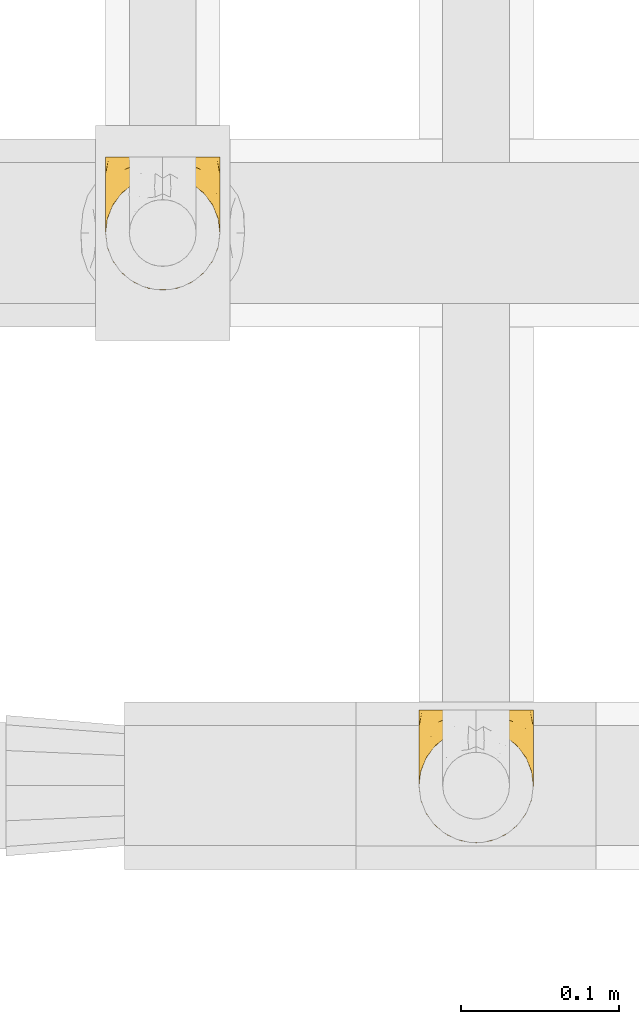
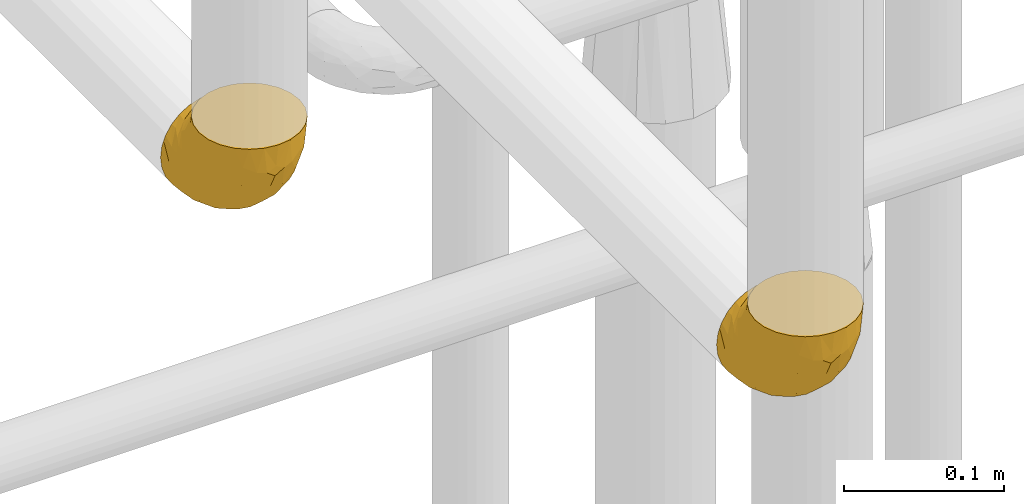
# One storey, part 127 of 827: 2 coverings.
"""IFC2X3 building model written with IfcOpenShell, lengths in millimetres."""

from ifc_helpers import new_model, entity, si_unit, converted_unit, derived_unit, direction, frame, origin, place, context, subcontext, project, spatial, faceted_brep, element, save


model = new_model("IFC2X3")

# Units and contexts
model_context = context("Model", 3, precision=0.01, world=origin(), true_north=direction((6.12303176911189e-17, 1.0)))
body_context = subcontext(model_context, "Body", "Model", "MODEL_VIEW")
ifc_project = project(units=[si_unit("LENGTHUNIT", "METRE", prefix="MILLI"), si_unit("AREAUNIT", "SQUARE_METRE"), si_unit("VOLUMEUNIT", "CUBIC_METRE"), converted_unit("PLANEANGLEUNIT", "DEGREE", entity("IfcRatioMeasure", 0.0174532925199433), si_unit("PLANEANGLEUNIT", "RADIAN"), dimensions=[0, 0, 0, 0, 0, 0, 0]), si_unit("MASSUNIT", "GRAM", prefix="KILO"), derived_unit("MASSDENSITYUNIT", [(si_unit("MASSUNIT", "GRAM", prefix="KILO"), 1), (si_unit("LENGTHUNIT", "METRE"), -3)]), derived_unit("MOMENTOFINERTIAUNIT", [(si_unit("LENGTHUNIT", "METRE"), 4)]), si_unit("TIMEUNIT", "SECOND"), si_unit("FREQUENCYUNIT", "HERTZ"), si_unit("THERMODYNAMICTEMPERATUREUNIT", "DEGREE_CELSIUS"), derived_unit("THERMALTRANSMITTANCEUNIT", [(si_unit("MASSUNIT", "GRAM", prefix="KILO"), 1), (si_unit("THERMODYNAMICTEMPERATUREUNIT", "KELVIN"), -1), (si_unit("TIMEUNIT", "SECOND"), -3)]), derived_unit("VOLUMETRICFLOWRATEUNIT", [(si_unit("LENGTHUNIT", "METRE"), 3), (si_unit("TIMEUNIT", "SECOND"), -1)]), derived_unit("MASSFLOWRATEUNIT", [(si_unit("MASSUNIT", "GRAM", prefix="KILO"), 1), (si_unit("TIMEUNIT", "SECOND"), -1)]), derived_unit("ROTATIONALFREQUENCYUNIT", [(si_unit("TIMEUNIT", "SECOND"), -1)]), si_unit("ELECTRICCURRENTUNIT", "AMPERE"), si_unit("ELECTRICVOLTAGEUNIT", "VOLT"), si_unit("POWERUNIT", "WATT"), si_unit("FORCEUNIT", "NEWTON", prefix="KILO"), si_unit("ILLUMINANCEUNIT", "LUX"), si_unit("LUMINOUSFLUXUNIT", "LUMEN"), si_unit("LUMINOUSINTENSITYUNIT", "CANDELA"), derived_unit("USERDEFINED", [(si_unit("MASSUNIT", "GRAM", prefix="KILO"), -1), (si_unit("LENGTHUNIT", "METRE"), -2), (si_unit("TIMEUNIT", "SECOND"), 3), (si_unit("LUMINOUSFLUXUNIT", "LUMEN"), 1)]), derived_unit("LINEARVELOCITYUNIT", [(si_unit("LENGTHUNIT", "METRE"), 1), (si_unit("TIMEUNIT", "SECOND"), -1)]), si_unit("PRESSUREUNIT", "PASCAL"), derived_unit("USERDEFINED", [(si_unit("LENGTHUNIT", "METRE"), -2), (si_unit("MASSUNIT", "GRAM", prefix="KILO"), 1), (si_unit("TIMEUNIT", "SECOND"), -2)]), derived_unit("LINEARFORCEUNIT", [(si_unit("MASSUNIT", "GRAM", prefix="KILO"), 1), (si_unit("LENGTHUNIT", "METRE"), 1), (si_unit("TIMEUNIT", "SECOND"), -2), (si_unit("LENGTHUNIT", "METRE"), -1)]), derived_unit("PLANARFORCEUNIT", [(si_unit("MASSUNIT", "GRAM", prefix="KILO"), 1), (si_unit("LENGTHUNIT", "METRE"), 1), (si_unit("TIMEUNIT", "SECOND"), -2), (si_unit("LENGTHUNIT", "METRE"), -2)])], contexts=[model_context])

# Site, building, storey
site_placement = place(None, origin())
site = spatial("IfcSite", under=ifc_project, at=site_placement, CompositionType="ELEMENT")
building_placement = place(site_placement, origin())
building = spatial("IfcBuilding", under=site, at=building_placement, CompositionType="ELEMENT")
storey_placement = place(building_placement, frame((0.0, 0.0, 28200.0)))
storey = spatial("IfcBuildingStorey", under=building, at=storey_placement, Name="08", CompositionType="ELEMENT", Elevation=28200.0)

# Coverings
covering_1_placement = place(storey_placement, frame((17030.57, 14712.0, 2362.2)))
element("IfcCovering", 1, at=covering_1_placement, inside=storey, Name=":ADSK_", ObjectType=":ADSK_", PredefinedType="INSULATION", context=body_context, shape_type="Brep", body=[
    faceted_brep([(74.0, 85.8, 37.8), (73.09, 85.8, 29.74), (70.41, 85.8, 22.08), (66.09, 85.8, 15.22), (60.36, 85.8, 9.49), (53.5, 85.8, 5.18), (45.85, 85.8, 2.5), (37.8, 85.8, 1.6), (29.74, 85.8, 2.5), (22.08, 85.8, 5.18), (15.22, 85.8, 9.5), (9.49, 85.8, 15.23), (5.18, 85.8, 22.09), (2.5, 85.8, 29.74), (1.6, 85.8, 37.8), (2.19, 85.8, 43.06), (2.5, 85.8, 45.85), (3.84, 85.8, 49.68), (5.18, 85.8, 53.51), (9.5, 85.8, 60.37), (15.23, 85.8, 66.1), (22.09, 85.8, 70.41), (29.74, 85.8, 73.09), (37.8, 85.8, 74.0), (45.85, 85.8, 73.09), (53.51, 85.8, 70.41), (60.37, 85.8, 66.09), (66.1, 85.8, 60.36), (70.41, 85.8, 53.5), (71.75, 85.8, 49.67), (73.09, 85.8, 45.85), (73.4, 85.8, 43.06), (28.43, 72.76, 85.8), (19.7, 69.15, 85.8), (12.2, 63.39, 85.8), (9.32, 59.64, 85.8), (6.45, 55.9, 85.8), (4.64, 51.53, 85.8), (2.83, 47.16, 85.8), (2.29, 43.08, 85.8), (1.94, 40.44, 85.8), (1.6, 37.8, 85.8), (2.83, 28.43, 85.8), (6.45, 19.7, 85.8), (12.2, 12.2, 85.8), (19.7, 6.45, 85.8), (28.43, 2.83, 85.8), (37.8, 1.6, 85.8), (47.16, 2.83, 85.8), (55.9, 6.45, 85.8), (63.39, 12.2, 85.8), (69.15, 19.7, 85.8), (72.76, 28.43, 85.8), (74.0, 37.8, 85.8), (73.3, 43.08, 85.8), (72.76, 47.16, 85.8), (70.95, 51.53, 85.8), (69.15, 55.9, 85.8), (66.27, 59.64, 85.8), (63.39, 63.39, 85.8), (55.9, 69.15, 85.8), (47.16, 72.76, 85.8), (37.8, 74.0, 85.8), (50.11, 27.78, 27.78), (37.8, 26.99, 26.99), (46.44, 36.07, 19.15), (37.8, 5.72, 59.78), (44.03, 4.9, 64.45), (37.8, 4.42, 67.99), (47.59, 13.52, 45.3), (57.17, 14.0, 53.86), (50.38, 6.28, 66.01), (58.65, 9.64, 70.92), (73.37, 70.93, 33.16), (71.27, 36.05, 49.16), (70.16, 24.02, 68.28), (66.97, 25.93, 50.64), (73.22, 32.56, 70.36), (74.0, 41.45, 67.43), (74.0, 39.97, 74.88), (74.0, 39.42, 77.61), (74.0, 38.88, 80.34), (64.86, 16.62, 65.68), (70.93, 71.64, 24.84), (45.19, 47.83, 11.5), (48.57, 65.91, 5.67), (54.32, 51.38, 13.35), (72.94, 52.81, 39.73), (74.0, 67.43, 41.45), (74.0, 63.53, 44.05), (74.0, 59.64, 46.65), (74.0, 55.75, 49.25), (74.0, 51.85, 51.85), (68.72, 41.26, 35.98), (73.34, 38.98, 57.18), (67.28, 70.65, 18.48), (61.7, 65.64, 13.36), (55.94, 71.08, 7.85), (37.8, 67.99, 4.42), (53.02, 38.62, 20.15), (57.31, 28.73, 31.91), (74.0, 80.34, 38.88), (74.0, 74.88, 39.97), (64.86, 52.52, 21.9), (59.15, 41.68, 22.4), (70.05, 56.44, 28.44), (55.98, 19.89, 41.69), (37.8, 11.7, 48.04), (63.54, 34.04, 33.67), (61.4, 22.66, 44.49), (37.8, 59.78, 5.72), (37.8, 36.3, 17.68), (37.8, 48.04, 11.7), (74.0, 49.25, 55.75), (74.0, 46.65, 59.64), (74.0, 44.05, 63.53), (37.8, 17.68, 36.3), (70.9, 56.47, 69.92), (69.2, 60.92, 69.03), (65.83, 63.29, 74.68), (73.31, 45.31, 79.55), (67.07, 59.83, 79.54), (62.53, 64.71, 81.25), (52.3, 74.49, 76.19), (54.94, 76.83, 72.4), (46.54, 78.01, 75.54), (72.14, 62.31, 57.77), (70.14, 62.83, 63.89), (73.22, 56.53, 57.73), (59.32, 71.99, 72.9), (56.36, 70.83, 77.88), (48.99, 73.18, 80.8), (58.36, 68.29, 80.78), (66.05, 80.74, 60.93), (61.56, 78.17, 66.56), (68.98, 73.83, 58.7), (73.26, 76.96, 46.01), (70.05, 54.72, 80.23), (73.39, 47.37, 70.42), (70.87, 54.39, 74.75), (61.17, 74.3, 68.99), (71.9, 75.54, 51.42), (65.19, 66.46, 71.01), (37.8, 80.75, 76.08), (46.04, 81.71, 73.72), (52.15, 81.69, 71.61), (66.57, 72.63, 63.33), (37.8, 77.45, 77.45), (73.34, 62.19, 52.1), (72.91, 67.73, 50.98), (37.8, 76.08, 80.75), (72.75, 48.26, 76.87), (66.28, 68.86, 66.53), (73.17, 50.18, 66.91), (72.08, 56.9, 63.7), (17.23, 68.29, 80.78), (26.6, 73.17, 80.8), (13.06, 64.71, 81.26), (1.6, 80.34, 38.88), (1.6, 74.88, 39.97), (29.56, 81.71, 73.72), (20.66, 76.83, 72.41), (23.45, 81.69, 71.61), (14.04, 78.17, 66.57), (1.6, 38.34, 83.07), (1.6, 39.97, 74.88), (1.6, 38.88, 80.34), (19.23, 70.83, 77.88), (23.3, 74.49, 76.2), (16.29, 72.0, 72.91), (8.09, 59.87, 77.2), (4.72, 54.39, 74.75), (5.54, 54.72, 80.23), (3.69, 75.53, 51.43), (2.84, 48.26, 76.87), (2.42, 50.18, 66.92), (4.69, 56.47, 69.93), (3.51, 56.9, 63.71), (2.2, 47.37, 70.42), (29.05, 78.01, 75.54), (2.29, 45.31, 79.55), (9.55, 80.74, 60.94), (14.43, 74.3, 69.0), (2.33, 76.96, 46.02), (3.45, 62.32, 57.77), (2.37, 56.54, 57.73), (5.45, 62.83, 63.89), (10.41, 66.46, 71.03), (2.81, 67.82, 51.53), (6.62, 73.83, 58.72), (1.6, 67.43, 41.45), (9.76, 63.29, 74.69), (9.03, 72.63, 63.35), (1.6, 55.75, 49.25), (4.15, 67.39, 56.44), (2.17, 62.12, 51.59), (1.6, 63.53, 44.05), (1.6, 46.65, 59.64), (1.6, 49.25, 55.75), (1.6, 41.45, 67.43), (1.6, 44.05, 63.53), (6.39, 60.93, 69.03), (9.32, 68.85, 66.54), (1.6, 59.64, 46.65), (1.6, 51.85, 51.85), (4.32, 36.06, 49.16), (2.37, 32.56, 70.36), (2.25, 38.98, 57.19), (16.43, 41.69, 22.41), (18.27, 28.73, 31.92), (12.04, 34.05, 33.68), (8.62, 25.93, 50.63), (6.87, 41.26, 35.99), (10.72, 52.53, 21.91), (2.64, 52.81, 39.73), (25.48, 27.78, 27.78), (19.59, 19.9, 41.7), (5.43, 24.02, 68.28), (31.57, 4.9, 64.45), (25.21, 6.28, 66.0), (5.53, 56.45, 28.45), (16.94, 9.64, 70.92), (10.73, 16.62, 65.68), (18.42, 14.0, 53.85), (21.26, 51.38, 13.35), (27.01, 65.91, 5.67), (30.39, 47.82, 11.5), (2.22, 70.94, 33.16), (13.88, 65.64, 13.37), (8.3, 70.65, 18.49), (28.0, 13.52, 45.3), (29.14, 36.08, 19.14), (22.56, 38.62, 20.15), (19.64, 71.07, 7.85), (14.18, 22.68, 44.48), (4.66, 71.64, 24.85)], [[[0, 1, 2, 3, 4, 5, 6, 7, 8, 9, 10, 11, 12, 13, 14, 15, 16, 17, 18, 19, 20, 21, 22, 23, 24, 25, 26, 27, 28, 29, 30, 31]], [[32, 33, 34, 35, 36, 37, 38, 39, 40, 41, 42, 43, 44, 45, 46, 47, 48, 49, 50, 51, 52, 53, 54, 55, 56, 57, 58, 59, 60, 61, 62]], [[63, 64, 65]], [[66, 67, 68]], [[69, 70, 71]], [[71, 70, 72]], [[73, 1, 0]], [[74, 75, 76]], [[49, 48, 71]], [[77, 78, 79, 80, 81, 53]], [[50, 82, 51]], [[72, 50, 49]], [[2, 1, 83]], [[84, 85, 86]], [[87, 88, 89, 90, 91, 92]], [[53, 52, 77]], [[93, 74, 76]], [[5, 85, 6]], [[94, 78, 77]], [[95, 3, 2]], [[95, 96, 3]], [[75, 51, 82]], [[85, 5, 97]], [[50, 72, 82]], [[97, 5, 4]], [[85, 98, 6]], [[94, 87, 92]], [[74, 77, 75]], [[99, 100, 63]], [[96, 4, 3]], [[73, 0, 101, 102, 88]], [[96, 103, 104]], [[48, 68, 67]], [[84, 99, 65]], [[105, 83, 73]], [[105, 95, 83]], [[100, 106, 63]], [[86, 96, 104]], [[97, 86, 85]], [[67, 107, 69]], [[100, 108, 109]], [[84, 110, 85]], [[93, 87, 74]], [[96, 95, 103]], [[69, 71, 67]], [[70, 69, 106]], [[4, 96, 97]], [[86, 97, 96]], [[83, 95, 2]], [[103, 95, 105]], [[93, 103, 105]], [[103, 108, 104]], [[75, 77, 52]], [[94, 77, 74]], [[51, 75, 52]], [[75, 82, 76]], [[109, 82, 70]], [[93, 76, 108]], [[88, 87, 73]], [[105, 73, 87]], [[84, 86, 99]], [[84, 111, 112, 110]], [[98, 85, 110]], [[98, 7, 6]], [[73, 83, 1]], [[71, 72, 49]], [[82, 72, 70]], [[87, 94, 74]], [[94, 92, 113, 114, 115, 78]], [[48, 47, 68]], [[48, 67, 71]], [[100, 104, 108]], [[99, 86, 104]], [[109, 108, 76]], [[100, 109, 106]], [[82, 109, 76]], [[106, 109, 70]], [[100, 99, 104]], [[99, 63, 65]], [[69, 116, 63]], [[111, 84, 65]], [[64, 63, 116]], [[64, 111, 65]], [[63, 106, 69]], [[103, 93, 108]], [[87, 93, 105]], [[107, 67, 66]], [[107, 116, 69]], [[117, 118, 119]], [[80, 120, 55]], [[121, 119, 122]], [[120, 56, 55]], [[123, 124, 125]], [[126, 127, 128]], [[101, 0, 31, 30, 102]], [[123, 129, 124]], [[130, 123, 131]], [[60, 122, 132]], [[133, 134, 135]], [[29, 28, 136]], [[132, 61, 60]], [[122, 60, 59]], [[137, 138, 139]], [[124, 129, 140]], [[133, 27, 26]], [[132, 131, 61]], [[141, 136, 28]], [[102, 29, 136]], [[119, 118, 142]], [[58, 137, 121]], [[141, 28, 27]], [[54, 53, 81, 80, 55]], [[23, 143, 144]], [[24, 145, 25]], [[25, 145, 134]], [[26, 25, 134]], [[135, 134, 146]], [[125, 143, 147]], [[124, 144, 125]], [[148, 90, 149]], [[124, 145, 144]], [[150, 125, 147]], [[151, 57, 56]], [[138, 78, 115]], [[131, 62, 61]], [[133, 141, 27]], [[127, 126, 152]], [[141, 135, 149]], [[149, 89, 141]], [[120, 78, 151]], [[115, 153, 138]], [[138, 137, 151]], [[78, 120, 80, 79]], [[151, 56, 120]], [[154, 114, 113]], [[153, 117, 139]], [[145, 24, 144]], [[134, 145, 124]], [[126, 91, 148]], [[146, 126, 135]], [[23, 144, 24]], [[143, 125, 144]], [[131, 125, 150]], [[129, 123, 130]], [[142, 130, 119]], [[124, 140, 134]], [[125, 131, 123]], [[62, 131, 150]], [[129, 152, 140]], [[146, 140, 152]], [[127, 152, 142]], [[153, 115, 114]], [[117, 153, 154]], [[118, 117, 154]], [[121, 117, 119]], [[139, 138, 153]], [[78, 138, 151]], [[127, 118, 154]], [[118, 127, 142]], [[152, 129, 142]], [[130, 142, 129]], [[102, 30, 29]], [[141, 88, 136]], [[88, 102, 136]], [[134, 133, 26]], [[141, 133, 135]], [[121, 122, 59]], [[132, 119, 130]], [[121, 59, 58]], [[121, 139, 117]], [[137, 58, 57]], [[151, 137, 57]], [[121, 137, 139]], [[119, 132, 122]], [[132, 130, 131]], [[140, 146, 134]], [[126, 146, 152]], [[89, 149, 90]], [[89, 88, 141]], [[148, 135, 126]], [[135, 148, 149]], [[114, 154, 153]], [[126, 128, 91]], [[91, 90, 148]], [[92, 128, 113]], [[128, 127, 154]], [[113, 128, 154]], [[91, 128, 92]], [[155, 32, 156]], [[33, 157, 34]], [[62, 150, 156]], [[15, 14, 158, 159, 16]], [[160, 23, 22]], [[161, 162, 163]], [[164, 41, 40, 39, 38, 165, 166]], [[167, 168, 169]], [[157, 170, 34]], [[171, 172, 170]], [[18, 173, 19]], [[174, 37, 36]], [[175, 176, 177]], [[178, 171, 175]], [[147, 179, 150]], [[168, 179, 161]], [[161, 160, 162]], [[162, 160, 22]], [[38, 37, 180]], [[20, 19, 181]], [[21, 20, 163]], [[161, 182, 169]], [[18, 183, 173]], [[184, 185, 186]], [[169, 187, 167]], [[188, 189, 173]], [[159, 190, 183]], [[17, 159, 183]], [[156, 179, 168]], [[191, 157, 155]], [[192, 163, 189]], [[21, 162, 22]], [[147, 143, 179]], [[181, 163, 20]], [[185, 184, 193]], [[178, 172, 171]], [[167, 156, 168]], [[184, 194, 195]], [[181, 173, 189]], [[173, 196, 188]], [[197, 177, 198]], [[199, 165, 180]], [[180, 165, 38]], [[200, 178, 175]], [[37, 174, 180]], [[199, 180, 174]], [[175, 197, 200]], [[177, 176, 201]], [[163, 162, 21]], [[160, 161, 179]], [[192, 184, 202]], [[194, 189, 188]], [[179, 143, 160]], [[23, 160, 143]], [[169, 168, 161]], [[155, 156, 167]], [[182, 161, 163]], [[202, 186, 187]], [[62, 156, 32]], [[179, 156, 150]], [[192, 182, 163]], [[202, 169, 182]], [[176, 175, 171]], [[174, 178, 199]], [[197, 175, 177]], [[170, 176, 171]], [[201, 176, 191]], [[199, 178, 200]], [[178, 174, 172]], [[187, 201, 191]], [[201, 187, 186]], [[167, 187, 191]], [[169, 202, 187]], [[173, 183, 190]], [[17, 16, 159]], [[173, 181, 19]], [[163, 181, 189]], [[155, 157, 33]], [[170, 157, 191]], [[176, 170, 191]], [[172, 36, 35]], [[36, 172, 174]], [[34, 170, 35]], [[170, 172, 35]], [[32, 155, 33]], [[191, 155, 167]], [[192, 189, 194]], [[182, 192, 202]], [[185, 198, 177]], [[183, 18, 17]], [[196, 173, 190]], [[196, 203, 188]], [[201, 186, 177]], [[202, 184, 186]], [[188, 195, 194]], [[204, 185, 193]], [[188, 203, 195]], [[192, 194, 184]], [[203, 193, 195]], [[184, 195, 193]], [[198, 185, 204]], [[186, 185, 177]], [[205, 206, 207]], [[208, 209, 210]], [[210, 211, 212]], [[210, 213, 208]], [[214, 204, 193, 203, 196, 190]], [[206, 41, 164, 166, 165, 199]], [[215, 216, 209]], [[206, 217, 42]], [[218, 46, 219]], [[207, 214, 205]], [[212, 214, 220]], [[221, 219, 45]], [[45, 219, 46]], [[221, 222, 223]], [[224, 225, 226]], [[222, 44, 43]], [[222, 217, 211]], [[220, 214, 227]], [[227, 190, 159, 158, 14]], [[217, 43, 42]], [[14, 13, 227]], [[225, 9, 8]], [[10, 228, 11]], [[11, 229, 12]], [[208, 213, 228]], [[228, 229, 11]], [[230, 219, 223]], [[231, 232, 226]], [[231, 64, 215]], [[225, 233, 9]], [[229, 213, 220]], [[233, 10, 9]], [[110, 225, 98]], [[41, 206, 42]], [[222, 211, 234]], [[224, 228, 233]], [[225, 8, 98]], [[221, 45, 44]], [[226, 110, 112, 111]], [[12, 229, 235]], [[46, 218, 68]], [[230, 107, 218]], [[223, 234, 216]], [[107, 66, 218]], [[224, 233, 225]], [[228, 10, 233]], [[213, 229, 228]], [[235, 229, 220]], [[208, 228, 224]], [[212, 213, 210]], [[207, 206, 199]], [[205, 211, 217]], [[205, 217, 206]], [[43, 217, 222]], [[212, 211, 205]], [[210, 209, 234]], [[227, 13, 235]], [[214, 190, 227]], [[110, 226, 225]], [[232, 231, 215]], [[8, 7, 98]], [[227, 235, 220]], [[13, 12, 235]], [[222, 221, 44]], [[219, 221, 223]], [[207, 199, 200, 197, 198, 204]], [[214, 207, 204]], [[68, 218, 66]], [[68, 47, 46]], [[230, 218, 219]], [[224, 232, 208]], [[208, 232, 209]], [[216, 215, 230]], [[210, 234, 211]], [[216, 234, 209]], [[222, 234, 223]], [[226, 232, 224]], [[209, 232, 215]], [[226, 111, 231]], [[64, 116, 215]], [[231, 111, 64]], [[116, 230, 215]], [[230, 223, 216]], [[214, 212, 205]], [[213, 212, 220]], [[230, 116, 107]]]),
])
covering_2_placement = place(storey_placement, frame((17228.92, 14362.2, 2362.2)))
element("IfcCovering", 2, at=covering_2_placement, inside=storey, Name=":ADSK_", ObjectType=":ADSK_", PredefinedType="INSULATION", context=body_context, shape_type="Brep", body=[
    faceted_brep([(74.0, 85.8, 37.8), (73.09, 85.8, 29.74), (70.41, 85.8, 22.08), (66.09, 85.8, 15.22), (60.36, 85.8, 9.49), (53.5, 85.8, 5.18), (45.85, 85.8, 2.5), (37.8, 85.8, 1.6), (29.74, 85.8, 2.5), (22.08, 85.8, 5.18), (15.22, 85.8, 9.5), (9.49, 85.8, 15.23), (5.18, 85.8, 22.09), (2.5, 85.8, 29.74), (1.6, 85.8, 37.8), (2.19, 85.8, 43.06), (2.5, 85.8, 45.85), (3.84, 85.8, 49.68), (5.18, 85.8, 53.51), (9.5, 85.8, 60.37), (15.23, 85.8, 66.1), (22.09, 85.8, 70.41), (29.74, 85.8, 73.09), (37.8, 85.8, 74.0), (45.85, 85.8, 73.09), (53.51, 85.8, 70.41), (60.37, 85.8, 66.09), (66.1, 85.8, 60.36), (70.41, 85.8, 53.5), (71.75, 85.8, 49.67), (73.09, 85.8, 45.85), (73.4, 85.8, 43.06), (28.43, 72.76, 85.8), (19.7, 69.15, 85.8), (12.2, 63.39, 85.8), (9.32, 59.64, 85.8), (6.45, 55.9, 85.8), (4.64, 51.53, 85.8), (2.83, 47.16, 85.8), (2.29, 43.08, 85.8), (1.94, 40.44, 85.8), (1.6, 37.8, 85.8), (2.83, 28.43, 85.8), (6.45, 19.7, 85.8), (12.2, 12.2, 85.8), (19.7, 6.45, 85.8), (28.43, 2.83, 85.8), (37.8, 1.6, 85.8), (47.16, 2.83, 85.8), (55.9, 6.45, 85.8), (63.39, 12.2, 85.8), (69.15, 19.7, 85.8), (72.76, 28.43, 85.8), (74.0, 37.8, 85.8), (73.3, 43.08, 85.8), (72.76, 47.16, 85.8), (70.95, 51.53, 85.8), (69.15, 55.9, 85.8), (66.27, 59.64, 85.8), (63.39, 63.39, 85.8), (55.9, 69.15, 85.8), (47.16, 72.76, 85.8), (37.8, 74.0, 85.8), (50.11, 27.78, 27.78), (37.8, 26.99, 26.99), (46.44, 36.07, 19.15), (37.8, 5.72, 59.78), (44.03, 4.9, 64.45), (37.8, 4.42, 67.99), (47.59, 13.52, 45.3), (57.17, 14.0, 53.86), (50.38, 6.28, 66.01), (58.65, 9.64, 70.92), (73.37, 70.93, 33.16), (71.27, 36.05, 49.16), (70.16, 24.02, 68.28), (66.97, 25.93, 50.64), (73.22, 32.56, 70.36), (74.0, 41.45, 67.43), (74.0, 39.97, 74.88), (74.0, 39.42, 77.61), (74.0, 38.88, 80.34), (64.86, 16.62, 65.68), (70.93, 71.64, 24.84), (45.19, 47.83, 11.5), (48.57, 65.91, 5.67), (54.32, 51.38, 13.35), (72.94, 52.81, 39.73), (74.0, 67.43, 41.45), (74.0, 63.53, 44.05), (74.0, 59.64, 46.65), (74.0, 55.75, 49.25), (74.0, 51.85, 51.85), (68.72, 41.26, 35.98), (73.34, 38.98, 57.18), (67.28, 70.65, 18.48), (61.7, 65.64, 13.36), (55.94, 71.08, 7.85), (37.8, 67.99, 4.42), (53.02, 38.62, 20.15), (57.31, 28.73, 31.91), (74.0, 80.34, 38.88), (74.0, 74.88, 39.97), (64.86, 52.52, 21.9), (59.15, 41.68, 22.4), (70.05, 56.44, 28.44), (55.98, 19.89, 41.69), (37.8, 11.7, 48.04), (63.54, 34.04, 33.67), (61.4, 22.66, 44.49), (37.8, 59.78, 5.72), (37.8, 36.3, 17.68), (37.8, 48.04, 11.7), (74.0, 49.25, 55.75), (74.0, 46.65, 59.64), (74.0, 44.05, 63.53), (37.8, 17.68, 36.3), (70.9, 56.47, 69.92), (69.2, 60.92, 69.03), (65.83, 63.29, 74.68), (73.31, 45.31, 79.55), (67.07, 59.83, 79.54), (62.53, 64.71, 81.25), (52.3, 74.49, 76.19), (54.94, 76.83, 72.4), (46.54, 78.01, 75.54), (72.14, 62.31, 57.77), (70.14, 62.83, 63.89), (73.22, 56.53, 57.73), (59.32, 71.99, 72.9), (56.36, 70.83, 77.88), (48.99, 73.18, 80.8), (58.36, 68.29, 80.78), (66.05, 80.74, 60.93), (61.56, 78.17, 66.56), (68.98, 73.83, 58.7), (73.26, 76.96, 46.01), (70.05, 54.72, 80.23), (73.39, 47.37, 70.42), (70.87, 54.39, 74.75), (61.17, 74.3, 68.99), (71.9, 75.54, 51.42), (65.19, 66.46, 71.01), (37.8, 80.75, 76.08), (46.04, 81.71, 73.72), (52.15, 81.69, 71.61), (66.57, 72.63, 63.33), (37.8, 77.45, 77.45), (73.34, 62.19, 52.1), (72.91, 67.73, 50.98), (37.8, 76.08, 80.75), (72.75, 48.26, 76.87), (66.28, 68.86, 66.53), (73.17, 50.18, 66.91), (72.08, 56.9, 63.7), (17.23, 68.29, 80.78), (26.6, 73.17, 80.8), (13.06, 64.71, 81.26), (1.6, 80.34, 38.88), (1.6, 74.88, 39.97), (29.56, 81.71, 73.72), (20.66, 76.83, 72.41), (23.45, 81.69, 71.61), (14.04, 78.17, 66.57), (1.6, 38.34, 83.07), (1.6, 39.97, 74.88), (1.6, 38.88, 80.34), (19.23, 70.83, 77.88), (23.3, 74.49, 76.2), (16.29, 72.0, 72.91), (8.09, 59.87, 77.2), (4.72, 54.39, 74.75), (5.54, 54.72, 80.23), (3.69, 75.53, 51.43), (2.84, 48.26, 76.87), (2.42, 50.18, 66.92), (4.69, 56.47, 69.93), (3.51, 56.9, 63.71), (2.2, 47.37, 70.42), (29.05, 78.01, 75.54), (2.29, 45.31, 79.55), (9.55, 80.74, 60.94), (14.43, 74.3, 69.0), (2.33, 76.96, 46.02), (3.45, 62.32, 57.77), (2.37, 56.54, 57.73), (5.45, 62.83, 63.89), (10.41, 66.46, 71.03), (2.81, 67.82, 51.53), (6.62, 73.83, 58.72), (1.6, 67.43, 41.45), (9.76, 63.29, 74.69), (9.03, 72.63, 63.35), (1.6, 55.75, 49.25), (4.15, 67.39, 56.44), (2.17, 62.12, 51.59), (1.6, 63.53, 44.05), (1.6, 46.65, 59.64), (1.6, 49.25, 55.75), (1.6, 41.45, 67.43), (1.6, 44.05, 63.53), (6.39, 60.93, 69.03), (9.32, 68.85, 66.54), (1.6, 59.64, 46.65), (1.6, 51.85, 51.85), (4.32, 36.06, 49.16), (2.37, 32.56, 70.36), (2.25, 38.98, 57.19), (16.43, 41.69, 22.41), (18.27, 28.73, 31.92), (12.04, 34.05, 33.68), (8.62, 25.93, 50.63), (6.87, 41.26, 35.99), (10.72, 52.53, 21.91), (2.64, 52.81, 39.73), (25.48, 27.78, 27.78), (19.59, 19.9, 41.7), (5.43, 24.02, 68.28), (31.57, 4.9, 64.45), (25.21, 6.28, 66.0), (5.53, 56.45, 28.45), (16.94, 9.64, 70.92), (10.73, 16.62, 65.68), (18.42, 14.0, 53.85), (21.26, 51.38, 13.35), (27.01, 65.91, 5.67), (30.39, 47.82, 11.5), (2.22, 70.94, 33.16), (13.88, 65.64, 13.37), (8.3, 70.65, 18.49), (28.0, 13.52, 45.3), (29.14, 36.08, 19.14), (22.56, 38.62, 20.15), (19.64, 71.07, 7.85), (14.18, 22.68, 44.48), (4.66, 71.64, 24.85)], [[[0, 1, 2, 3, 4, 5, 6, 7, 8, 9, 10, 11, 12, 13, 14, 15, 16, 17, 18, 19, 20, 21, 22, 23, 24, 25, 26, 27, 28, 29, 30, 31]], [[32, 33, 34, 35, 36, 37, 38, 39, 40, 41, 42, 43, 44, 45, 46, 47, 48, 49, 50, 51, 52, 53, 54, 55, 56, 57, 58, 59, 60, 61, 62]], [[63, 64, 65]], [[66, 67, 68]], [[69, 70, 71]], [[71, 70, 72]], [[73, 1, 0]], [[74, 75, 76]], [[49, 48, 71]], [[77, 78, 79, 80, 81, 53]], [[50, 82, 51]], [[72, 50, 49]], [[2, 1, 83]], [[84, 85, 86]], [[87, 88, 89, 90, 91, 92]], [[53, 52, 77]], [[93, 74, 76]], [[5, 85, 6]], [[94, 78, 77]], [[95, 3, 2]], [[95, 96, 3]], [[75, 51, 82]], [[85, 5, 97]], [[50, 72, 82]], [[97, 5, 4]], [[85, 98, 6]], [[94, 87, 92]], [[74, 77, 75]], [[99, 100, 63]], [[96, 4, 3]], [[73, 0, 101, 102, 88]], [[96, 103, 104]], [[48, 68, 67]], [[84, 99, 65]], [[105, 83, 73]], [[105, 95, 83]], [[100, 106, 63]], [[86, 96, 104]], [[97, 86, 85]], [[67, 107, 69]], [[100, 108, 109]], [[84, 110, 85]], [[93, 87, 74]], [[96, 95, 103]], [[69, 71, 67]], [[70, 69, 106]], [[4, 96, 97]], [[86, 97, 96]], [[83, 95, 2]], [[103, 95, 105]], [[93, 103, 105]], [[103, 108, 104]], [[75, 77, 52]], [[94, 77, 74]], [[51, 75, 52]], [[75, 82, 76]], [[109, 82, 70]], [[93, 76, 108]], [[88, 87, 73]], [[105, 73, 87]], [[84, 86, 99]], [[84, 111, 112, 110]], [[98, 85, 110]], [[98, 7, 6]], [[73, 83, 1]], [[71, 72, 49]], [[82, 72, 70]], [[87, 94, 74]], [[94, 92, 113, 114, 115, 78]], [[48, 47, 68]], [[48, 67, 71]], [[100, 104, 108]], [[99, 86, 104]], [[109, 108, 76]], [[100, 109, 106]], [[82, 109, 76]], [[106, 109, 70]], [[100, 99, 104]], [[99, 63, 65]], [[69, 116, 63]], [[111, 84, 65]], [[64, 63, 116]], [[64, 111, 65]], [[63, 106, 69]], [[103, 93, 108]], [[87, 93, 105]], [[107, 67, 66]], [[107, 116, 69]], [[117, 118, 119]], [[80, 120, 55]], [[121, 119, 122]], [[120, 56, 55]], [[123, 124, 125]], [[126, 127, 128]], [[101, 0, 31, 30, 102]], [[123, 129, 124]], [[130, 123, 131]], [[60, 122, 132]], [[133, 134, 135]], [[29, 28, 136]], [[132, 61, 60]], [[122, 60, 59]], [[137, 138, 139]], [[124, 129, 140]], [[133, 27, 26]], [[132, 131, 61]], [[141, 136, 28]], [[102, 29, 136]], [[119, 118, 142]], [[58, 137, 121]], [[141, 28, 27]], [[54, 53, 81, 80, 55]], [[23, 143, 144]], [[24, 145, 25]], [[25, 145, 134]], [[26, 25, 134]], [[135, 134, 146]], [[125, 143, 147]], [[124, 144, 125]], [[148, 90, 149]], [[124, 145, 144]], [[150, 125, 147]], [[151, 57, 56]], [[138, 78, 115]], [[131, 62, 61]], [[133, 141, 27]], [[127, 126, 152]], [[141, 135, 149]], [[149, 89, 141]], [[120, 78, 151]], [[115, 153, 138]], [[138, 137, 151]], [[78, 120, 80, 79]], [[151, 56, 120]], [[154, 114, 113]], [[153, 117, 139]], [[145, 24, 144]], [[134, 145, 124]], [[126, 91, 148]], [[146, 126, 135]], [[23, 144, 24]], [[143, 125, 144]], [[131, 125, 150]], [[129, 123, 130]], [[142, 130, 119]], [[124, 140, 134]], [[125, 131, 123]], [[62, 131, 150]], [[129, 152, 140]], [[146, 140, 152]], [[127, 152, 142]], [[153, 115, 114]], [[117, 153, 154]], [[118, 117, 154]], [[121, 117, 119]], [[139, 138, 153]], [[78, 138, 151]], [[127, 118, 154]], [[118, 127, 142]], [[152, 129, 142]], [[130, 142, 129]], [[102, 30, 29]], [[141, 88, 136]], [[88, 102, 136]], [[134, 133, 26]], [[141, 133, 135]], [[121, 122, 59]], [[132, 119, 130]], [[121, 59, 58]], [[121, 139, 117]], [[137, 58, 57]], [[151, 137, 57]], [[121, 137, 139]], [[119, 132, 122]], [[132, 130, 131]], [[140, 146, 134]], [[126, 146, 152]], [[89, 149, 90]], [[89, 88, 141]], [[148, 135, 126]], [[135, 148, 149]], [[114, 154, 153]], [[126, 128, 91]], [[91, 90, 148]], [[92, 128, 113]], [[128, 127, 154]], [[113, 128, 154]], [[91, 128, 92]], [[155, 32, 156]], [[33, 157, 34]], [[62, 150, 156]], [[15, 14, 158, 159, 16]], [[160, 23, 22]], [[161, 162, 163]], [[164, 41, 40, 39, 38, 165, 166]], [[167, 168, 169]], [[157, 170, 34]], [[171, 172, 170]], [[18, 173, 19]], [[174, 37, 36]], [[175, 176, 177]], [[178, 171, 175]], [[147, 179, 150]], [[168, 179, 161]], [[161, 160, 162]], [[162, 160, 22]], [[38, 37, 180]], [[20, 19, 181]], [[21, 20, 163]], [[161, 182, 169]], [[18, 183, 173]], [[184, 185, 186]], [[169, 187, 167]], [[188, 189, 173]], [[159, 190, 183]], [[17, 159, 183]], [[156, 179, 168]], [[191, 157, 155]], [[192, 163, 189]], [[21, 162, 22]], [[147, 143, 179]], [[181, 163, 20]], [[185, 184, 193]], [[178, 172, 171]], [[167, 156, 168]], [[184, 194, 195]], [[181, 173, 189]], [[173, 196, 188]], [[197, 177, 198]], [[199, 165, 180]], [[180, 165, 38]], [[200, 178, 175]], [[37, 174, 180]], [[199, 180, 174]], [[175, 197, 200]], [[177, 176, 201]], [[163, 162, 21]], [[160, 161, 179]], [[192, 184, 202]], [[194, 189, 188]], [[179, 143, 160]], [[23, 160, 143]], [[169, 168, 161]], [[155, 156, 167]], [[182, 161, 163]], [[202, 186, 187]], [[62, 156, 32]], [[179, 156, 150]], [[192, 182, 163]], [[202, 169, 182]], [[176, 175, 171]], [[174, 178, 199]], [[197, 175, 177]], [[170, 176, 171]], [[201, 176, 191]], [[199, 178, 200]], [[178, 174, 172]], [[187, 201, 191]], [[201, 187, 186]], [[167, 187, 191]], [[169, 202, 187]], [[173, 183, 190]], [[17, 16, 159]], [[173, 181, 19]], [[163, 181, 189]], [[155, 157, 33]], [[170, 157, 191]], [[176, 170, 191]], [[172, 36, 35]], [[36, 172, 174]], [[34, 170, 35]], [[170, 172, 35]], [[32, 155, 33]], [[191, 155, 167]], [[192, 189, 194]], [[182, 192, 202]], [[185, 198, 177]], [[183, 18, 17]], [[196, 173, 190]], [[196, 203, 188]], [[201, 186, 177]], [[202, 184, 186]], [[188, 195, 194]], [[204, 185, 193]], [[188, 203, 195]], [[192, 194, 184]], [[203, 193, 195]], [[184, 195, 193]], [[198, 185, 204]], [[186, 185, 177]], [[205, 206, 207]], [[208, 209, 210]], [[210, 211, 212]], [[210, 213, 208]], [[214, 204, 193, 203, 196, 190]], [[206, 41, 164, 166, 165, 199]], [[215, 216, 209]], [[206, 217, 42]], [[218, 46, 219]], [[207, 214, 205]], [[212, 214, 220]], [[221, 219, 45]], [[45, 219, 46]], [[221, 222, 223]], [[224, 225, 226]], [[222, 44, 43]], [[222, 217, 211]], [[220, 214, 227]], [[227, 190, 159, 158, 14]], [[217, 43, 42]], [[14, 13, 227]], [[225, 9, 8]], [[10, 228, 11]], [[11, 229, 12]], [[208, 213, 228]], [[228, 229, 11]], [[230, 219, 223]], [[231, 232, 226]], [[231, 64, 215]], [[225, 233, 9]], [[229, 213, 220]], [[233, 10, 9]], [[110, 225, 98]], [[41, 206, 42]], [[222, 211, 234]], [[224, 228, 233]], [[225, 8, 98]], [[221, 45, 44]], [[226, 110, 112, 111]], [[12, 229, 235]], [[46, 218, 68]], [[230, 107, 218]], [[223, 234, 216]], [[107, 66, 218]], [[224, 233, 225]], [[228, 10, 233]], [[213, 229, 228]], [[235, 229, 220]], [[208, 228, 224]], [[212, 213, 210]], [[207, 206, 199]], [[205, 211, 217]], [[205, 217, 206]], [[43, 217, 222]], [[212, 211, 205]], [[210, 209, 234]], [[227, 13, 235]], [[214, 190, 227]], [[110, 226, 225]], [[232, 231, 215]], [[8, 7, 98]], [[227, 235, 220]], [[13, 12, 235]], [[222, 221, 44]], [[219, 221, 223]], [[207, 199, 200, 197, 198, 204]], [[214, 207, 204]], [[68, 218, 66]], [[68, 47, 46]], [[230, 218, 219]], [[224, 232, 208]], [[208, 232, 209]], [[216, 215, 230]], [[210, 234, 211]], [[216, 234, 209]], [[222, 234, 223]], [[226, 232, 224]], [[209, 232, 215]], [[226, 111, 231]], [[64, 116, 215]], [[231, 111, 64]], [[116, 230, 215]], [[230, 223, 216]], [[214, 212, 205]], [[213, 212, 220]], [[230, 116, 107]]]),
])

save(model, "model.ifc")
